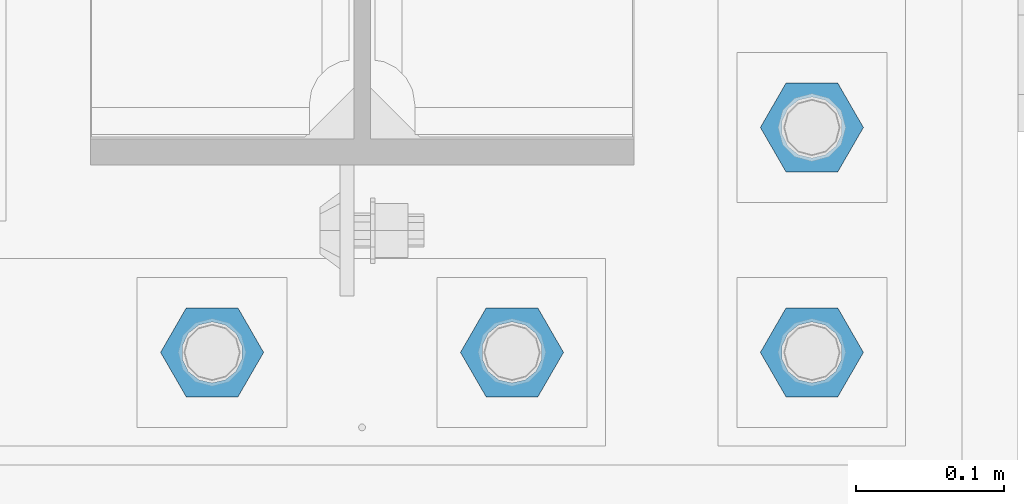
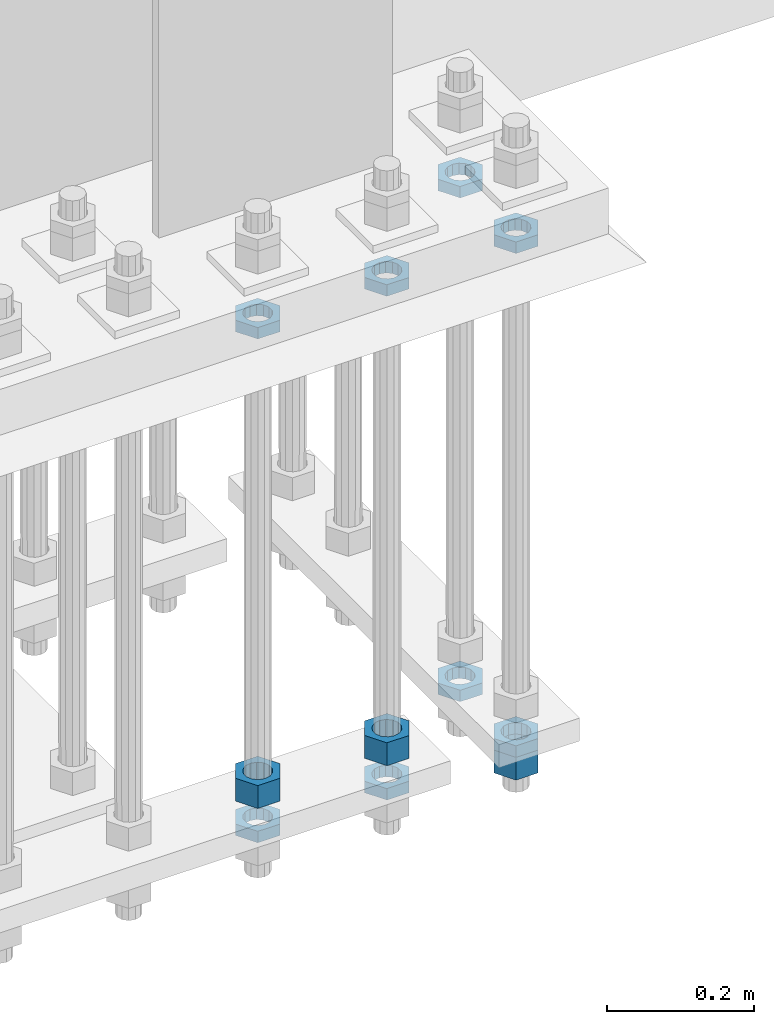
# One storey, part 2832 of 3843: 11 beams, 1 element without a shape of its own.
"""IFC2X3 building model written with IfcOpenShell, lengths in millimetres."""

from ifc_helpers import new_model, si_unit, frame, origin_with_axes, place, context, subcontext, project, spatial, faceted_brep, material, type_object, element, aggregate, save


model = new_model("IFC2X3")

# Units and contexts
model_context = context("Model", 3, precision=1e-05, world=origin_with_axes())
body_context = subcontext(model_context, "Body", "Model", "MODEL_VIEW")
ifc_project = project(units=[si_unit("LENGTHUNIT", "METRE", prefix="MILLI"), si_unit("AREAUNIT", "SQUARE_METRE"), si_unit("VOLUMEUNIT", "CUBIC_METRE"), si_unit("MASSUNIT", "GRAM", prefix="KILO"), si_unit("TIMEUNIT", "SECOND"), si_unit("PLANEANGLEUNIT", "RADIAN"), si_unit("SOLIDANGLEUNIT", "STERADIAN"), si_unit("THERMODYNAMICTEMPERATUREUNIT", "DEGREE_CELSIUS"), si_unit("LUMINOUSINTENSITYUNIT", "LUMEN")], contexts=[model_context])

# Site, building, storey
site_placement = place(None, origin_with_axes())
site = spatial("IfcSite", under=ifc_project, at=site_placement, CompositionType="ELEMENT")
building_placement = place(site_placement, origin_with_axes())
building = spatial("IfcBuilding", under=site, at=building_placement, Name="Undefined", CompositionType="ELEMENT")
storey_placement = place(building_placement, origin_with_axes())
storey = spatial("IfcBuildingStorey", under=building, at=storey_placement, Name="Undefined", CompositionType="ELEMENT", Elevation=0.0)

# Assembly, beams
assembly_placement = place(storey_placement, origin_with_axes())
assembly = element("IfcElementAssembly", 1, at=assembly_placement, inside=storey, Name="TEMPLATE", AssemblyPlace="NOTDEFINED", PredefinedType="RIGID_FRAME")
ifc_material = material(Name="STEEL/A572-50")
beam_type_1 = type_object("IfcBeamType", Name="1-1/2_HEAVY_HEX_NUT", PredefinedType="NOTDEFINED")
beam_1_placement = place(assembly_placement, frame((62738.0, 25311.1, 28841.7000015259), z_axis=(0.0, -1.0, 0.0), x_axis=(0.0, 0.0, -1.0)))
beam_1 = element("IfcBeam", 2, at=beam_1_placement, type_object=beam_type_1, material=ifc_material, Name="NUT", ObjectType="1-1/2_HEAVY_HEX_NUT", context=body_context, shape_type="Brep", body=[
    faceted_brep([(0.0, -34.9199981689453, 0.0), (0.0, -17.4599990844727, -30.25), (38.0999999999985, -17.4599990844727, -30.25), (38.0999999999985, -34.9199981689453, 0.0), (0.0, 17.4599990844727, -30.25), (38.0999999999985, 17.4599990844727, -30.25), (0.0, 34.9199981689453, 0.0), (38.0999999999985, 34.9199981689453, 0.0), (0.0, 17.4599990844727, 30.25), (38.0999999999985, 17.4599990844727, 30.25), (0.0, -17.4599990844727, 30.25), (38.0999999999985, -17.4599990844727, 30.25), (0.0, 0.0, 20.6399993896484), (0.0, 8.9553601105581, 18.5959968835959), (38.0999999999985, 8.9553601105581, 18.5959968835959), (38.0999999999985, 0.0, 20.6399993896484), (0.0, 16.1370013209525, 12.8688291298167), (38.0999999999985, 16.1370013209525, 12.8688291298167), (0.0, 20.1225115123816, 4.59283194104501), (38.0999999999985, 20.1225115123816, 4.59283194104501), (0.0, 20.1225115123816, -4.59283194104501), (38.0999999999985, 20.1225115123816, -4.59283194104501), (0.0, 16.1370013209525, -12.8688291298167), (38.0999999999985, 16.1370013209525, -12.8688291298167), (0.0, 8.9553601105581, -18.5959968835959), (38.0999999999985, 8.9553601105581, -18.5959968835959), (0.0, 0.0, -20.6399993896484), (38.0999999999985, 0.0, -20.6399993896484), (0.0, -8.9553601105581, -18.5959968835959), (38.0999999999985, -8.9553601105581, -18.5959968835959), (0.0, -16.1370013209525, -12.8688291298167), (38.0999999999985, -16.1370013209525, -12.8688291298167), (0.0, -20.1225115123816, -4.59283194104501), (38.0999999999985, -20.1225115123816, -4.59283194104501), (0.0, -20.1225115123816, 4.59283194104501), (38.0999999999985, -20.1225115123816, 4.59283194104501), (0.0, -16.1370013209525, 12.8688291298167), (38.0999999999985, -16.1370013209525, 12.8688291298167), (0.0, -8.9553601105581, 18.5959968835959), (38.0999999999985, -8.9553601105581, 18.5959968835959)], [[[0, 1, 2, 3]], [[1, 4, 5, 2]], [[4, 6, 7, 5]], [[6, 8, 9, 7]], [[8, 10, 11, 9]], [[10, 0, 3, 11]], [[12, 13, 14, 15]], [[13, 16, 17, 14]], [[16, 18, 19, 17]], [[18, 20, 21, 19]], [[20, 22, 23, 21]], [[22, 24, 25, 23]], [[24, 26, 27, 25]], [[26, 28, 29, 27]], [[28, 30, 31, 29]], [[30, 32, 33, 31]], [[32, 34, 35, 33]], [[34, 36, 37, 35]], [[36, 38, 39, 37]], [[38, 12, 15, 39]], [[5, 7, 9, 11, 3, 2], [17, 19, 21, 23, 25, 27, 29, 31, 33, 35, 37, 39, 15, 14]], [[10, 8, 6, 4, 1, 0], [38, 36, 34, 32, 30, 28, 26, 24, 22, 20, 18, 16, 13, 12]]]),
])
beam_2_placement = place(assembly_placement, frame((62534.8, 25311.1, 28841.7000015259), z_axis=(0.0, -1.0, 0.0), x_axis=(0.0, 0.0, -1.0)))
beam_2 = element("IfcBeam", 3, at=beam_2_placement, type_object=beam_type_1, material=ifc_material, Name="NUT", ObjectType="1-1/2_HEAVY_HEX_NUT", context=body_context, shape_type="Brep", body=[
    faceted_brep([(0.0, -34.9199981689453, 0.0), (0.0, -17.4599990844727, -30.25), (38.0999999999985, -17.4599990844727, -30.25), (38.0999999999985, -34.9199981689453, 0.0), (0.0, 17.4599990844727, -30.25), (38.0999999999985, 17.4599990844727, -30.25), (0.0, 34.9199981689453, 0.0), (38.0999999999985, 34.9199981689453, 0.0), (0.0, 17.4599990844727, 30.25), (38.0999999999985, 17.4599990844727, 30.25), (0.0, -17.4599990844727, 30.25), (38.0999999999985, -17.4599990844727, 30.25), (0.0, 0.0, 20.6399993896484), (0.0, 8.9553601105581, 18.5959968835959), (38.0999999999985, 8.9553601105581, 18.5959968835959), (38.0999999999985, 0.0, 20.6399993896484), (0.0, 16.1370013209525, 12.8688291298167), (38.0999999999985, 16.1370013209525, 12.8688291298167), (0.0, 20.1225115123816, 4.59283194104501), (38.0999999999985, 20.1225115123816, 4.59283194104501), (0.0, 20.1225115123816, -4.59283194104501), (38.0999999999985, 20.1225115123816, -4.59283194104501), (0.0, 16.1370013209525, -12.8688291298167), (38.0999999999985, 16.1370013209525, -12.8688291298167), (0.0, 8.9553601105581, -18.5959968835959), (38.0999999999985, 8.9553601105581, -18.5959968835959), (0.0, 0.0, -20.6399993896484), (38.0999999999985, 0.0, -20.6399993896484), (0.0, -8.9553601105581, -18.5959968835959), (38.0999999999985, -8.9553601105581, -18.5959968835959), (0.0, -16.1370013209525, -12.8688291298167), (38.0999999999985, -16.1370013209525, -12.8688291298167), (0.0, -20.1225115123816, -4.59283194104501), (38.0999999999985, -20.1225115123816, -4.59283194104501), (0.0, -20.1225115123816, 4.59283194104501), (38.0999999999985, -20.1225115123816, 4.59283194104501), (0.0, -16.1370013209525, 12.8688291298167), (38.0999999999985, -16.1370013209525, 12.8688291298167), (0.0, -8.9553601105581, 18.5959968835959), (38.0999999999985, -8.9553601105581, 18.5959968835959)], [[[0, 1, 2, 3]], [[1, 4, 5, 2]], [[4, 6, 7, 5]], [[6, 8, 9, 7]], [[8, 10, 11, 9]], [[10, 0, 3, 11]], [[12, 13, 14, 15]], [[13, 16, 17, 14]], [[16, 18, 19, 17]], [[18, 20, 21, 19]], [[20, 22, 23, 21]], [[22, 24, 25, 23]], [[24, 26, 27, 25]], [[26, 28, 29, 27]], [[28, 30, 31, 29]], [[30, 32, 33, 31]], [[32, 34, 35, 33]], [[34, 36, 37, 35]], [[36, 38, 39, 37]], [[38, 12, 15, 39]], [[5, 7, 9, 11, 3, 2], [17, 19, 21, 23, 25, 27, 29, 31, 33, 35, 37, 39, 15, 14]], [[10, 8, 6, 4, 1, 0], [38, 36, 34, 32, 30, 28, 26, 24, 22, 20, 18, 16, 13, 12]]]),
])
beam_3_placement = place(assembly_placement, frame((62941.2, 25311.1, 28746.4500015259), z_axis=(0.0, -1.0, 0.0), x_axis=(0.0, 0.0, -1.0)))
beam_3 = element("IfcBeam", 4, at=beam_3_placement, type_object=beam_type_1, material=ifc_material, Name="NUT", ObjectType="1-1/2_HEAVY_HEX_NUT", context=body_context, shape_type="Brep", body=[
    faceted_brep([(0.0, -34.9199981689453, 0.0), (0.0, -17.4599990844727, -30.25), (38.0999999999985, -17.4599990844727, -30.25), (38.0999999999985, -34.9199981689453, 0.0), (0.0, 17.4599990844727, -30.25), (38.0999999999985, 17.4599990844727, -30.25), (0.0, 34.9199981689453, 0.0), (38.0999999999985, 34.9199981689453, 0.0), (0.0, 17.4599990844727, 30.25), (38.0999999999985, 17.4599990844727, 30.25), (0.0, -17.4599990844727, 30.25), (38.0999999999985, -17.4599990844727, 30.25), (0.0, 0.0, 20.6399993896484), (0.0, 8.9553601105581, 18.5959968835959), (38.0999999999985, 8.9553601105581, 18.5959968835959), (38.0999999999985, 0.0, 20.6399993896484), (0.0, 16.1370013209525, 12.8688291298167), (38.0999999999985, 16.1370013209525, 12.8688291298167), (0.0, 20.1225115123816, 4.59283194104501), (38.0999999999985, 20.1225115123816, 4.59283194104501), (0.0, 20.1225115123816, -4.59283194104501), (38.0999999999985, 20.1225115123816, -4.59283194104501), (0.0, 16.1370013209525, -12.8688291298167), (38.0999999999985, 16.1370013209525, -12.8688291298167), (0.0, 8.9553601105581, -18.5959968835959), (38.0999999999985, 8.9553601105581, -18.5959968835959), (0.0, 0.0, -20.6399993896484), (38.0999999999985, 0.0, -20.6399993896484), (0.0, -8.9553601105581, -18.5959968835959), (38.0999999999985, -8.9553601105581, -18.5959968835959), (0.0, -16.1370013209525, -12.8688291298167), (38.0999999999985, -16.1370013209525, -12.8688291298167), (0.0, -20.1225115123816, -4.59283194104501), (38.0999999999985, -20.1225115123816, -4.59283194104501), (0.0, -20.1225115123816, 4.59283194104501), (38.0999999999985, -20.1225115123816, 4.59283194104501), (0.0, -16.1370013209525, 12.8688291298167), (38.0999999999985, -16.1370013209525, 12.8688291298167), (0.0, -8.9553601105581, 18.5959968835959), (38.0999999999985, -8.9553601105581, 18.5959968835959)], [[[0, 1, 2, 3]], [[1, 4, 5, 2]], [[4, 6, 7, 5]], [[6, 8, 9, 7]], [[8, 10, 11, 9]], [[10, 0, 3, 11]], [[12, 13, 14, 15]], [[13, 16, 17, 14]], [[16, 18, 19, 17]], [[18, 20, 21, 19]], [[20, 22, 23, 21]], [[22, 24, 25, 23]], [[24, 26, 27, 25]], [[26, 28, 29, 27]], [[28, 30, 31, 29]], [[30, 32, 33, 31]], [[32, 34, 35, 33]], [[34, 36, 37, 35]], [[36, 38, 39, 37]], [[38, 12, 15, 39]], [[5, 7, 9, 11, 3, 2], [17, 19, 21, 23, 25, 27, 29, 31, 33, 35, 37, 39, 15, 14]], [[10, 8, 6, 4, 1, 0], [38, 36, 34, 32, 30, 28, 26, 24, 22, 20, 18, 16, 13, 12]]]),
])
beam_type_2 = type_object("IfcBeamType", Name="1-1/2_HALF_NUT", PredefinedType="NOTDEFINED")
beam_4_placement = place(assembly_placement, frame((62534.8, 25311.1, 29603.7), z_axis=(0.0, -1.0, 0.0), x_axis=(0.0, 0.0, -1.0)))
beam_4 = element("IfcBeam", 5, at=beam_4_placement, type_object=beam_type_2, material=ifc_material, Name="NUT", ObjectType="1-1/2_HALF_NUT", context=body_context, shape_type="Brep", body=[
    faceted_brep([(0.0, -34.9199981689453, 0.0), (0.0, -17.4599990844727, -30.25), (19.0500000000029, -17.4599990844727, -30.25), (19.0500000000029, -34.9199981689453, 0.0), (0.0, 17.4599990844727, -30.25), (19.0500000000029, 17.4599990844727, -30.25), (0.0, 34.9199981689453, 0.0), (19.0500000000029, 34.9199981689453, 0.0), (0.0, 17.4599990844727, 30.25), (19.0500000000029, 17.4599990844727, 30.25), (0.0, -17.4599990844727, 30.25), (19.0500000000029, -17.4599990844727, 30.25), (0.0, 0.0, 20.6399993896484), (0.0, 8.9553601105581, 18.5959968835959), (19.0500000000029, 8.95536011056538, 18.5959968835959), (19.0500000000029, 0.0, 20.6399993896484), (0.0, 16.1370013209525, 12.8688291298167), (19.0500000000029, 16.1370013209489, 12.8688291298167), (0.0, 20.1225115123816, 4.59283194104501), (19.0500000000029, 20.1225115123852, 4.59283194104501), (0.0, 20.1225115123816, -4.59283194104501), (19.0500000000029, 20.1225115123852, -4.59283194104501), (0.0, 16.1370013209525, -12.8688291298167), (19.0500000000029, 16.1370013209489, -12.8688291298167), (0.0, 8.9553601105581, -18.5959968835959), (19.0500000000029, 8.95536011056538, -18.5959968835959), (0.0, 0.0, -20.6399993896484), (19.0500000000029, 0.0, -20.6399993896484), (0.0, -8.9553601105581, -18.5959968835959), (19.0500000000029, -8.95536011056538, -18.5959968835959), (0.0, -16.1370013209525, -12.8688291298167), (19.0500000000029, -16.1370013209489, -12.8688291298167), (0.0, -20.1225115123816, -4.59283194104501), (19.0500000000029, -20.1225115123852, -4.59283194104501), (0.0, -20.1225115123816, 4.59283194104501), (19.0500000000029, -20.1225115123852, 4.59283194104501), (0.0, -16.1370013209525, 12.8688291298167), (19.0500000000029, -16.1370013209489, 12.8688291298167), (0.0, -8.9553601105581, 18.5959968835959), (19.0500000000029, -8.95536011056538, 18.5959968835959)], [[[0, 1, 2, 3]], [[1, 4, 5, 2]], [[4, 6, 7, 5]], [[6, 8, 9, 7]], [[8, 10, 11, 9]], [[10, 0, 3, 11]], [[12, 13, 14, 15]], [[13, 16, 17, 14]], [[16, 18, 19, 17]], [[18, 20, 21, 19]], [[20, 22, 23, 21]], [[22, 24, 25, 23]], [[24, 26, 27, 25]], [[26, 28, 29, 27]], [[28, 30, 31, 29]], [[30, 32, 33, 31]], [[32, 34, 35, 33]], [[34, 36, 37, 35]], [[36, 38, 39, 37]], [[38, 12, 15, 39]], [[5, 7, 9, 11, 3, 2], [17, 19, 21, 23, 25, 27, 29, 31, 33, 35, 37, 39, 15, 14]], [[10, 8, 6, 4, 1, 0], [38, 36, 34, 32, 30, 28, 26, 24, 22, 20, 18, 16, 13, 12]]]),
])
beam_5_placement = place(assembly_placement, frame((62738.0, 25311.1, 29603.7), z_axis=(0.0, 1.0, 0.0), x_axis=(0.0, 0.0, -1.0)))
beam_5 = element("IfcBeam", 6, at=beam_5_placement, type_object=beam_type_2, material=ifc_material, Name="NUT", ObjectType="1-1/2_HALF_NUT", context=body_context, shape_type="Brep", body=[
    faceted_brep([(0.0, -34.9199981689453, 0.0), (0.0, -17.4599990844727, -30.25), (19.0500000000029, -17.4599990844727, -30.25), (19.0500000000029, -34.9199981689453, 0.0), (0.0, 17.4599990844727, -30.25), (19.0500000000029, 17.4599990844727, -30.25), (0.0, 34.9199981689453, 0.0), (19.0500000000029, 34.9199981689453, 0.0), (0.0, 17.4599990844727, 30.25), (19.0500000000029, 17.4599990844727, 30.25), (0.0, -17.4599990844727, 30.25), (19.0500000000029, -17.4599990844727, 30.25), (0.0, 0.0, 20.6399993896484), (0.0, 8.9553601105581, 18.5959968835959), (19.0500000000029, 8.95536011056538, 18.5959968835959), (19.0500000000029, 0.0, 20.6399993896484), (0.0, 16.1370013209525, 12.8688291298167), (19.0500000000029, 16.1370013209489, 12.8688291298167), (0.0, 20.1225115123816, 4.59283194104501), (19.0500000000029, 20.1225115123852, 4.59283194104501), (0.0, 20.1225115123816, -4.59283194104501), (19.0500000000029, 20.1225115123852, -4.59283194104501), (0.0, 16.1370013209525, -12.8688291298167), (19.0500000000029, 16.1370013209489, -12.8688291298167), (0.0, 8.9553601105581, -18.5959968835959), (19.0500000000029, 8.95536011056538, -18.5959968835959), (0.0, 0.0, -20.6399993896484), (19.0500000000029, 0.0, -20.6399993896484), (0.0, -8.9553601105581, -18.5959968835959), (19.0500000000029, -8.95536011056538, -18.5959968835959), (0.0, -16.1370013209525, -12.8688291298167), (19.0500000000029, -16.1370013209489, -12.8688291298167), (0.0, -20.1225115123816, -4.59283194104501), (19.0500000000029, -20.1225115123852, -4.59283194104501), (0.0, -20.1225115123816, 4.59283194104501), (19.0500000000029, -20.1225115123852, 4.59283194104501), (0.0, -16.1370013209525, 12.8688291298167), (19.0500000000029, -16.1370013209489, 12.8688291298167), (0.0, -8.9553601105581, 18.5959968835959), (19.0500000000029, -8.95536011056538, 18.5959968835959)], [[[0, 1, 2, 3]], [[1, 4, 5, 2]], [[4, 6, 7, 5]], [[6, 8, 9, 7]], [[8, 10, 11, 9]], [[10, 0, 3, 11]], [[12, 13, 14, 15]], [[13, 16, 17, 14]], [[16, 18, 19, 17]], [[18, 20, 21, 19]], [[20, 22, 23, 21]], [[22, 24, 25, 23]], [[24, 26, 27, 25]], [[26, 28, 29, 27]], [[28, 30, 31, 29]], [[30, 32, 33, 31]], [[32, 34, 35, 33]], [[34, 36, 37, 35]], [[36, 38, 39, 37]], [[38, 12, 15, 39]], [[5, 7, 9, 11, 3, 2], [17, 19, 21, 23, 25, 27, 29, 31, 33, 35, 37, 39, 15, 14]], [[10, 8, 6, 4, 1, 0], [38, 36, 34, 32, 30, 28, 26, 24, 22, 20, 18, 16, 13, 12]]]),
])
beam_6_placement = place(assembly_placement, frame((62941.2, 25311.1, 29603.7), z_axis=(0.0, 1.0, 0.0), x_axis=(0.0, 0.0, -1.0)))
beam_6 = element("IfcBeam", 7, at=beam_6_placement, type_object=beam_type_2, material=ifc_material, Name="NUT", ObjectType="1-1/2_HALF_NUT", context=body_context, shape_type="Brep", body=[
    faceted_brep([(0.0, -34.9199981689453, 0.0), (0.0, -17.4599990844727, -30.25), (19.0500000000029, -17.4599990844727, -30.25), (19.0500000000029, -34.9199981689453, 0.0), (0.0, 17.4599990844727, -30.25), (19.0500000000029, 17.4599990844727, -30.25), (0.0, 34.9199981689453, 0.0), (19.0500000000029, 34.9199981689453, 0.0), (0.0, 17.4599990844727, 30.25), (19.0500000000029, 17.4599990844727, 30.25), (0.0, -17.4599990844727, 30.25), (19.0500000000029, -17.4599990844727, 30.25), (0.0, 0.0, 20.6399993896484), (0.0, 8.9553601105581, 18.5959968835959), (19.0500000000029, 8.95536011056538, 18.5959968835959), (19.0500000000029, 0.0, 20.6399993896484), (0.0, 16.1370013209525, 12.8688291298167), (19.0500000000029, 16.1370013209489, 12.8688291298167), (0.0, 20.1225115123816, 4.59283194104501), (19.0500000000029, 20.1225115123852, 4.59283194104501), (0.0, 20.1225115123816, -4.59283194104501), (19.0500000000029, 20.1225115123852, -4.59283194104501), (0.0, 16.1370013209525, -12.8688291298167), (19.0500000000029, 16.1370013209489, -12.8688291298167), (0.0, 8.9553601105581, -18.5959968835959), (19.0500000000029, 8.95536011056538, -18.5959968835959), (0.0, 0.0, -20.6399993896484), (19.0500000000029, 0.0, -20.6399993896484), (0.0, -8.9553601105581, -18.5959968835959), (19.0500000000029, -8.95536011056538, -18.5959968835959), (0.0, -16.1370013209525, -12.8688291298167), (19.0500000000029, -16.1370013209489, -12.8688291298167), (0.0, -20.1225115123816, -4.59283194104501), (19.0500000000029, -20.1225115123852, -4.59283194104501), (0.0, -20.1225115123816, 4.59283194104501), (19.0500000000029, -20.1225115123852, 4.59283194104501), (0.0, -16.1370013209525, 12.8688291298167), (19.0500000000029, -16.1370013209489, 12.8688291298167), (0.0, -8.9553601105581, 18.5959968835959), (19.0500000000029, -8.95536011056538, 18.5959968835959)], [[[0, 1, 2, 3]], [[1, 4, 5, 2]], [[4, 6, 7, 5]], [[6, 8, 9, 7]], [[8, 10, 11, 9]], [[10, 0, 3, 11]], [[12, 13, 14, 15]], [[13, 16, 17, 14]], [[16, 18, 19, 17]], [[18, 20, 21, 19]], [[20, 22, 23, 21]], [[22, 24, 25, 23]], [[24, 26, 27, 25]], [[26, 28, 29, 27]], [[28, 30, 31, 29]], [[30, 32, 33, 31]], [[32, 34, 35, 33]], [[34, 36, 37, 35]], [[36, 38, 39, 37]], [[38, 12, 15, 39]], [[5, 7, 9, 11, 3, 2], [17, 19, 21, 23, 25, 27, 29, 31, 33, 35, 37, 39, 15, 14]], [[10, 8, 6, 4, 1, 0], [38, 36, 34, 32, 30, 28, 26, 24, 22, 20, 18, 16, 13, 12]]]),
])
beam_7_placement = place(assembly_placement, frame((62941.2, 25463.5, 29603.7), z_axis=(0.0, 1.0, 0.0), x_axis=(0.0, 0.0, -1.0)))
beam_7 = element("IfcBeam", 8, at=beam_7_placement, type_object=beam_type_2, material=ifc_material, Name="NUT", ObjectType="1-1/2_HALF_NUT", context=body_context, shape_type="Brep", body=[
    faceted_brep([(0.0, -34.9199981689453, 0.0), (0.0, -17.4599990844727, -30.25), (19.0500000000029, -17.4599990844727, -30.25), (19.0500000000029, -34.9199981689453, 0.0), (0.0, 17.4599990844727, -30.25), (19.0500000000029, 17.4599990844727, -30.25), (0.0, 34.9199981689453, 0.0), (19.0500000000029, 34.9199981689453, 0.0), (0.0, 17.4599990844727, 30.25), (19.0500000000029, 17.4599990844727, 30.25), (0.0, -17.4599990844727, 30.25), (19.0500000000029, -17.4599990844727, 30.25), (0.0, 0.0, 20.6399993896484), (0.0, 8.9553601105581, 18.5959968835959), (19.0500000000029, 8.95536011056538, 18.5959968835959), (19.0500000000029, 0.0, 20.6399993896484), (0.0, 16.1370013209525, 12.8688291298167), (19.0500000000029, 16.1370013209489, 12.8688291298167), (0.0, 20.1225115123816, 4.59283194104501), (19.0500000000029, 20.1225115123852, 4.59283194104501), (0.0, 20.1225115123816, -4.59283194104501), (19.0500000000029, 20.1225115123852, -4.59283194104501), (0.0, 16.1370013209525, -12.8688291298167), (19.0500000000029, 16.1370013209489, -12.8688291298167), (0.0, 8.9553601105581, -18.5959968835959), (19.0500000000029, 8.95536011056538, -18.5959968835959), (0.0, 0.0, -20.6399993896484), (19.0500000000029, 0.0, -20.6399993896484), (0.0, -8.9553601105581, -18.5959968835959), (19.0500000000029, -8.95536011056538, -18.5959968835959), (0.0, -16.1370013209525, -12.8688291298167), (19.0500000000029, -16.1370013209489, -12.8688291298167), (0.0, -20.1225115123816, -4.59283194104501), (19.0500000000029, -20.1225115123852, -4.59283194104501), (0.0, -20.1225115123816, 4.59283194104501), (19.0500000000029, -20.1225115123852, 4.59283194104501), (0.0, -16.1370013209525, 12.8688291298167), (19.0500000000029, -16.1370013209489, 12.8688291298167), (0.0, -8.9553601105581, 18.5959968835959), (19.0500000000029, -8.95536011056538, 18.5959968835959)], [[[0, 1, 2, 3]], [[1, 4, 5, 2]], [[4, 6, 7, 5]], [[6, 8, 9, 7]], [[8, 10, 11, 9]], [[10, 0, 3, 11]], [[12, 13, 14, 15]], [[13, 16, 17, 14]], [[16, 18, 19, 17]], [[18, 20, 21, 19]], [[20, 22, 23, 21]], [[22, 24, 25, 23]], [[24, 26, 27, 25]], [[26, 28, 29, 27]], [[28, 30, 31, 29]], [[30, 32, 33, 31]], [[32, 34, 35, 33]], [[34, 36, 37, 35]], [[36, 38, 39, 37]], [[38, 12, 15, 39]], [[5, 7, 9, 11, 3, 2], [17, 19, 21, 23, 25, 27, 29, 31, 33, 35, 37, 39, 15, 14]], [[10, 8, 6, 4, 1, 0], [38, 36, 34, 32, 30, 28, 26, 24, 22, 20, 18, 16, 13, 12]]]),
])
beam_8_placement = place(assembly_placement, frame((62941.2, 25311.1, 28765.5000015259), z_axis=(0.0, -1.0, 0.0), x_axis=(0.0, 0.0, -1.0)))
beam_8 = element("IfcBeam", 9, at=beam_8_placement, type_object=beam_type_2, material=ifc_material, Name="NUT", ObjectType="1-1/2_HALF_NUT", context=body_context, shape_type="Brep", body=[
    faceted_brep([(0.0, -34.9199981689453, 0.0), (0.0, -17.4599990844727, -30.25), (19.0500000000029, -17.4599990844727, -30.25), (19.0500000000029, -34.9199981689453, 0.0), (0.0, 17.4599990844727, -30.25), (19.0500000000029, 17.4599990844727, -30.25), (0.0, 34.9199981689453, 0.0), (19.0500000000029, 34.9199981689453, 0.0), (0.0, 17.4599990844727, 30.25), (19.0500000000029, 17.4599990844727, 30.25), (0.0, -17.4599990844727, 30.25), (19.0500000000029, -17.4599990844727, 30.25), (0.0, 0.0, 20.6399993896484), (0.0, 8.9553601105581, 18.5959968835959), (19.0500000000029, 8.95536011056538, 18.5959968835959), (19.0500000000029, 0.0, 20.6399993896484), (0.0, 16.1370013209525, 12.8688291298167), (19.0500000000029, 16.1370013209489, 12.8688291298167), (0.0, 20.1225115123816, 4.59283194104501), (19.0500000000029, 20.1225115123852, 4.59283194104501), (0.0, 20.1225115123816, -4.59283194104501), (19.0500000000029, 20.1225115123852, -4.59283194104501), (0.0, 16.1370013209525, -12.8688291298167), (19.0500000000029, 16.1370013209489, -12.8688291298167), (0.0, 8.9553601105581, -18.5959968835959), (19.0500000000029, 8.95536011056538, -18.5959968835959), (0.0, 0.0, -20.6399993896484), (19.0500000000029, 0.0, -20.6399993896484), (0.0, -8.9553601105581, -18.5959968835959), (19.0500000000029, -8.95536011056538, -18.5959968835959), (0.0, -16.1370013209525, -12.8688291298167), (19.0500000000029, -16.1370013209489, -12.8688291298167), (0.0, -20.1225115123816, -4.59283194104501), (19.0500000000029, -20.1225115123852, -4.59283194104501), (0.0, -20.1225115123816, 4.59283194104501), (19.0500000000029, -20.1225115123852, 4.59283194104501), (0.0, -16.1370013209525, 12.8688291298167), (19.0500000000029, -16.1370013209489, 12.8688291298167), (0.0, -8.9553601105581, 18.5959968835959), (19.0500000000029, -8.95536011056538, 18.5959968835959)], [[[0, 1, 2, 3]], [[1, 4, 5, 2]], [[4, 6, 7, 5]], [[6, 8, 9, 7]], [[8, 10, 11, 9]], [[10, 0, 3, 11]], [[12, 13, 14, 15]], [[13, 16, 17, 14]], [[16, 18, 19, 17]], [[18, 20, 21, 19]], [[20, 22, 23, 21]], [[22, 24, 25, 23]], [[24, 26, 27, 25]], [[26, 28, 29, 27]], [[28, 30, 31, 29]], [[30, 32, 33, 31]], [[32, 34, 35, 33]], [[34, 36, 37, 35]], [[36, 38, 39, 37]], [[38, 12, 15, 39]], [[5, 7, 9, 11, 3, 2], [17, 19, 21, 23, 25, 27, 29, 31, 33, 35, 37, 39, 15, 14]], [[10, 8, 6, 4, 1, 0], [38, 36, 34, 32, 30, 28, 26, 24, 22, 20, 18, 16, 13, 12]]]),
])
beam_9_placement = place(assembly_placement, frame((62738.0, 25311.1, 28765.5000015259), z_axis=(0.0, -1.0, 0.0), x_axis=(0.0, 0.0, -1.0)))
beam_9 = element("IfcBeam", 10, at=beam_9_placement, type_object=beam_type_2, material=ifc_material, Name="NUT", ObjectType="1-1/2_HALF_NUT", context=body_context, shape_type="Brep", body=[
    faceted_brep([(0.0, -34.9199981689453, 0.0), (0.0, -17.4599990844727, -30.25), (19.0500000000029, -17.4599990844727, -30.25), (19.0500000000029, -34.9199981689453, 0.0), (0.0, 17.4599990844727, -30.25), (19.0500000000029, 17.4599990844727, -30.25), (0.0, 34.9199981689453, 0.0), (19.0500000000029, 34.9199981689453, 0.0), (0.0, 17.4599990844727, 30.25), (19.0500000000029, 17.4599990844727, 30.25), (0.0, -17.4599990844727, 30.25), (19.0500000000029, -17.4599990844727, 30.25), (0.0, 0.0, 20.6399993896484), (0.0, 8.9553601105581, 18.5959968835959), (19.0500000000029, 8.95536011056538, 18.5959968835959), (19.0500000000029, 0.0, 20.6399993896484), (0.0, 16.1370013209525, 12.8688291298167), (19.0500000000029, 16.1370013209489, 12.8688291298167), (0.0, 20.1225115123816, 4.59283194104501), (19.0500000000029, 20.1225115123852, 4.59283194104501), (0.0, 20.1225115123816, -4.59283194104501), (19.0500000000029, 20.1225115123852, -4.59283194104501), (0.0, 16.1370013209525, -12.8688291298167), (19.0500000000029, 16.1370013209489, -12.8688291298167), (0.0, 8.9553601105581, -18.5959968835959), (19.0500000000029, 8.95536011056538, -18.5959968835959), (0.0, 0.0, -20.6399993896484), (19.0500000000029, 0.0, -20.6399993896484), (0.0, -8.9553601105581, -18.5959968835959), (19.0500000000029, -8.95536011056538, -18.5959968835959), (0.0, -16.1370013209525, -12.8688291298167), (19.0500000000029, -16.1370013209489, -12.8688291298167), (0.0, -20.1225115123816, -4.59283194104501), (19.0500000000029, -20.1225115123852, -4.59283194104501), (0.0, -20.1225115123816, 4.59283194104501), (19.0500000000029, -20.1225115123852, 4.59283194104501), (0.0, -16.1370013209525, 12.8688291298167), (19.0500000000029, -16.1370013209489, 12.8688291298167), (0.0, -8.9553601105581, 18.5959968835959), (19.0500000000029, -8.95536011056538, 18.5959968835959)], [[[0, 1, 2, 3]], [[1, 4, 5, 2]], [[4, 6, 7, 5]], [[6, 8, 9, 7]], [[8, 10, 11, 9]], [[10, 0, 3, 11]], [[12, 13, 14, 15]], [[13, 16, 17, 14]], [[16, 18, 19, 17]], [[18, 20, 21, 19]], [[20, 22, 23, 21]], [[22, 24, 25, 23]], [[24, 26, 27, 25]], [[26, 28, 29, 27]], [[28, 30, 31, 29]], [[30, 32, 33, 31]], [[32, 34, 35, 33]], [[34, 36, 37, 35]], [[36, 38, 39, 37]], [[38, 12, 15, 39]], [[5, 7, 9, 11, 3, 2], [17, 19, 21, 23, 25, 27, 29, 31, 33, 35, 37, 39, 15, 14]], [[10, 8, 6, 4, 1, 0], [38, 36, 34, 32, 30, 28, 26, 24, 22, 20, 18, 16, 13, 12]]]),
])
beam_10_placement = place(assembly_placement, frame((62534.8, 25311.1, 28765.5000015259), z_axis=(0.0, -1.0, 0.0), x_axis=(0.0, 0.0, -1.0)))
beam_10 = element("IfcBeam", 11, at=beam_10_placement, type_object=beam_type_2, material=ifc_material, Name="NUT", ObjectType="1-1/2_HALF_NUT", context=body_context, shape_type="Brep", body=[
    faceted_brep([(0.0, -34.9199981689453, 0.0), (0.0, -17.4599990844727, -30.25), (19.0500000000029, -17.4599990844727, -30.25), (19.0500000000029, -34.9199981689453, 0.0), (0.0, 17.4599990844727, -30.25), (19.0500000000029, 17.4599990844727, -30.25), (0.0, 34.9199981689453, 0.0), (19.0500000000029, 34.9199981689453, 0.0), (0.0, 17.4599990844727, 30.25), (19.0500000000029, 17.4599990844727, 30.25), (0.0, -17.4599990844727, 30.25), (19.0500000000029, -17.4599990844727, 30.25), (0.0, 0.0, 20.6399993896484), (0.0, 8.9553601105581, 18.5959968835959), (19.0500000000029, 8.95536011056538, 18.5959968835959), (19.0500000000029, 0.0, 20.6399993896484), (0.0, 16.1370013209525, 12.8688291298167), (19.0500000000029, 16.1370013209489, 12.8688291298167), (0.0, 20.1225115123816, 4.59283194104501), (19.0500000000029, 20.1225115123852, 4.59283194104501), (0.0, 20.1225115123816, -4.59283194104501), (19.0500000000029, 20.1225115123852, -4.59283194104501), (0.0, 16.1370013209525, -12.8688291298167), (19.0500000000029, 16.1370013209489, -12.8688291298167), (0.0, 8.9553601105581, -18.5959968835959), (19.0500000000029, 8.95536011056538, -18.5959968835959), (0.0, 0.0, -20.6399993896484), (19.0500000000029, 0.0, -20.6399993896484), (0.0, -8.9553601105581, -18.5959968835959), (19.0500000000029, -8.95536011056538, -18.5959968835959), (0.0, -16.1370013209525, -12.8688291298167), (19.0500000000029, -16.1370013209489, -12.8688291298167), (0.0, -20.1225115123816, -4.59283194104501), (19.0500000000029, -20.1225115123852, -4.59283194104501), (0.0, -20.1225115123816, 4.59283194104501), (19.0500000000029, -20.1225115123852, 4.59283194104501), (0.0, -16.1370013209525, 12.8688291298167), (19.0500000000029, -16.1370013209489, 12.8688291298167), (0.0, -8.9553601105581, 18.5959968835959), (19.0500000000029, -8.95536011056538, 18.5959968835959)], [[[0, 1, 2, 3]], [[1, 4, 5, 2]], [[4, 6, 7, 5]], [[6, 8, 9, 7]], [[8, 10, 11, 9]], [[10, 0, 3, 11]], [[12, 13, 14, 15]], [[13, 16, 17, 14]], [[16, 18, 19, 17]], [[18, 20, 21, 19]], [[20, 22, 23, 21]], [[22, 24, 25, 23]], [[24, 26, 27, 25]], [[26, 28, 29, 27]], [[28, 30, 31, 29]], [[30, 32, 33, 31]], [[32, 34, 35, 33]], [[34, 36, 37, 35]], [[36, 38, 39, 37]], [[38, 12, 15, 39]], [[5, 7, 9, 11, 3, 2], [17, 19, 21, 23, 25, 27, 29, 31, 33, 35, 37, 39, 15, 14]], [[10, 8, 6, 4, 1, 0], [38, 36, 34, 32, 30, 28, 26, 24, 22, 20, 18, 16, 13, 12]]]),
])
beam_11_placement = place(assembly_placement, frame((62941.2, 25463.5, 28765.5000015259), z_axis=(0.0, -1.0, 0.0), x_axis=(0.0, 0.0, -1.0)))
beam_11 = element("IfcBeam", 12, at=beam_11_placement, type_object=beam_type_2, material=ifc_material, Name="NUT", ObjectType="1-1/2_HALF_NUT", context=body_context, shape_type="Brep", body=[
    faceted_brep([(0.0, -34.9199981689453, 0.0), (0.0, -17.4599990844727, -30.25), (19.0500000000029, -17.4599990844727, -30.25), (19.0500000000029, -34.9199981689453, 0.0), (0.0, 17.4599990844727, -30.25), (19.0500000000029, 17.4599990844727, -30.25), (0.0, 34.9199981689453, 0.0), (19.0500000000029, 34.9199981689453, 0.0), (0.0, 17.4599990844727, 30.25), (19.0500000000029, 17.4599990844727, 30.25), (0.0, -17.4599990844727, 30.25), (19.0500000000029, -17.4599990844727, 30.25), (0.0, 0.0, 20.6399993896484), (0.0, 8.9553601105581, 18.5959968835959), (19.0500000000029, 8.95536011056538, 18.5959968835959), (19.0500000000029, 0.0, 20.6399993896484), (0.0, 16.1370013209525, 12.8688291298167), (19.0500000000029, 16.1370013209489, 12.8688291298167), (0.0, 20.1225115123816, 4.59283194104501), (19.0500000000029, 20.1225115123852, 4.59283194104501), (0.0, 20.1225115123816, -4.59283194104501), (19.0500000000029, 20.1225115123852, -4.59283194104501), (0.0, 16.1370013209525, -12.8688291298167), (19.0500000000029, 16.1370013209489, -12.8688291298167), (0.0, 8.9553601105581, -18.5959968835959), (19.0500000000029, 8.95536011056538, -18.5959968835959), (0.0, 0.0, -20.6399993896484), (19.0500000000029, 0.0, -20.6399993896484), (0.0, -8.9553601105581, -18.5959968835959), (19.0500000000029, -8.95536011056538, -18.5959968835959), (0.0, -16.1370013209525, -12.8688291298167), (19.0500000000029, -16.1370013209489, -12.8688291298167), (0.0, -20.1225115123816, -4.59283194104501), (19.0500000000029, -20.1225115123852, -4.59283194104501), (0.0, -20.1225115123816, 4.59283194104501), (19.0500000000029, -20.1225115123852, 4.59283194104501), (0.0, -16.1370013209525, 12.8688291298167), (19.0500000000029, -16.1370013209489, 12.8688291298167), (0.0, -8.9553601105581, 18.5959968835959), (19.0500000000029, -8.95536011056538, 18.5959968835959)], [[[0, 1, 2, 3]], [[1, 4, 5, 2]], [[4, 6, 7, 5]], [[6, 8, 9, 7]], [[8, 10, 11, 9]], [[10, 0, 3, 11]], [[12, 13, 14, 15]], [[13, 16, 17, 14]], [[16, 18, 19, 17]], [[18, 20, 21, 19]], [[20, 22, 23, 21]], [[22, 24, 25, 23]], [[24, 26, 27, 25]], [[26, 28, 29, 27]], [[28, 30, 31, 29]], [[30, 32, 33, 31]], [[32, 34, 35, 33]], [[34, 36, 37, 35]], [[36, 38, 39, 37]], [[38, 12, 15, 39]], [[5, 7, 9, 11, 3, 2], [17, 19, 21, 23, 25, 27, 29, 31, 33, 35, 37, 39, 15, 14]], [[10, 8, 6, 4, 1, 0], [38, 36, 34, 32, 30, 28, 26, 24, 22, 20, 18, 16, 13, 12]]]),
])
aggregate(assembly, [beam_1, beam_2, beam_4, beam_5, beam_6, beam_7, beam_8, beam_9, beam_10, beam_11, beam_3])

save(model, "model.ifc")
